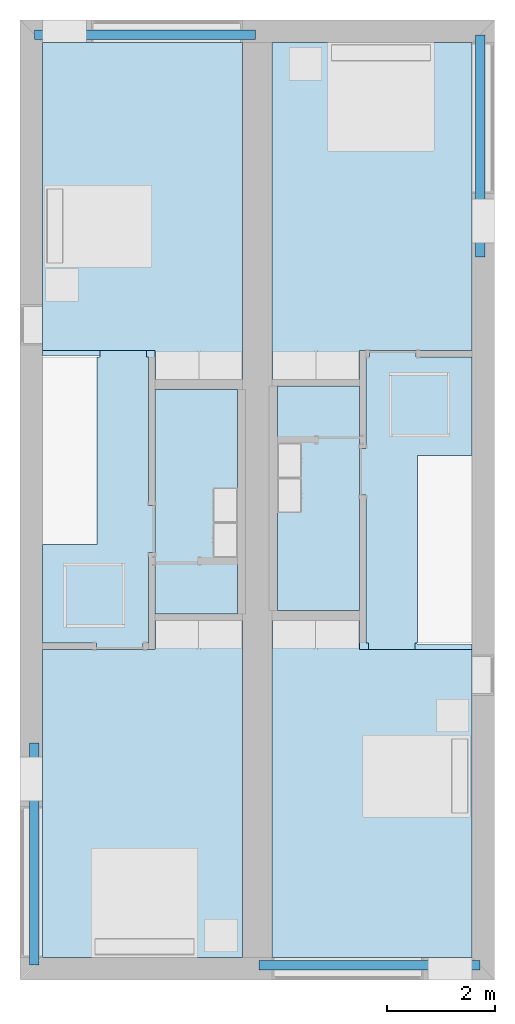
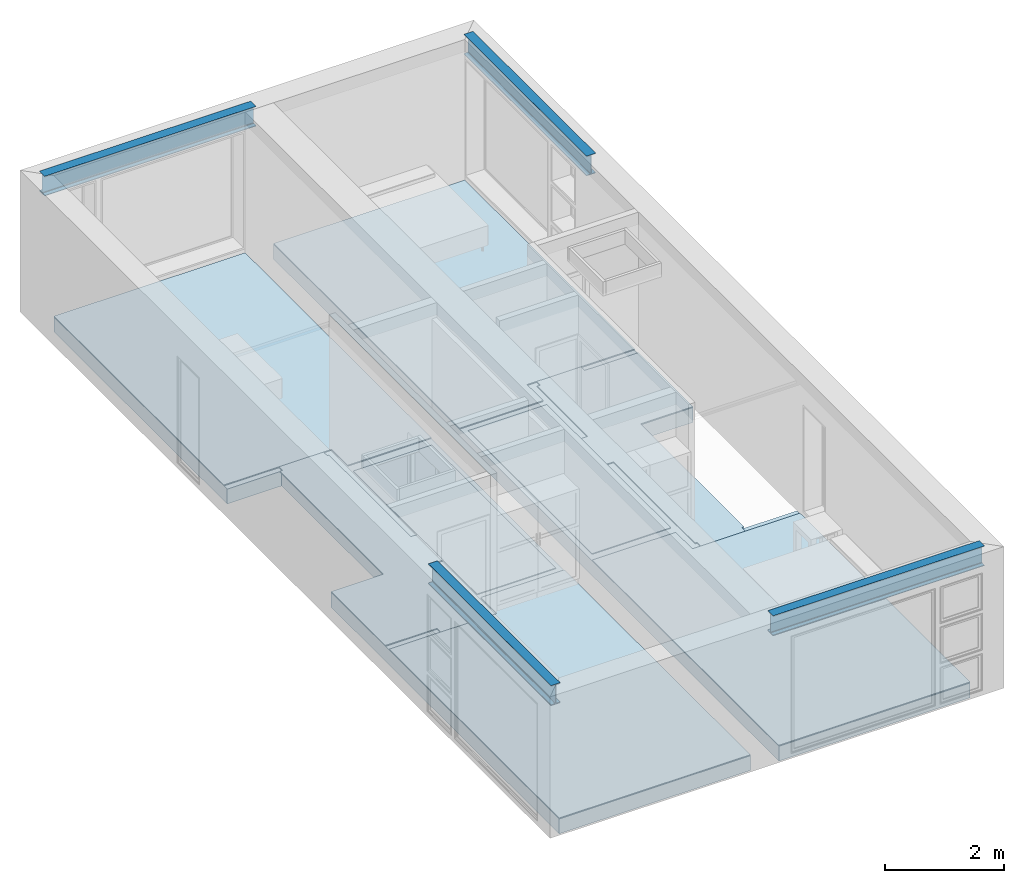
# One storey, part 1 of 16: 10 slabs, 4 beams.
"""IFC2X3 building model written with IfcOpenShell, lengths in metres."""

from ifc_helpers import new_model, entity, si_unit, converted_unit, frame, frame_2d, origin, place, context, project, spatial, polyline, circle_curve, parameter, trimmed, segment, composite_curve, rectangle, outline, extrude, material, layer, layer_set, layer_usage, element, save


model = new_model("IFC2X3")

# Units and contexts
model_context = context("Model", 3, precision=1e-09, world=origin())
plan_context = context("Plan", 3, precision=1e-09, world=origin())
ifc_project = project(units=[si_unit("LENGTHUNIT", "METRE"), si_unit("AREAUNIT", "SQUARE_METRE"), si_unit("VOLUMEUNIT", "CUBIC_METRE"), converted_unit("PLANEANGLEUNIT", "DEGREE", entity("IfcRatioMeasure", 0.01745329251994328), si_unit("PLANEANGLEUNIT", "RADIAN"), dimensions=[0, 0, 0, 0, 0, 0, 0]), si_unit("TIMEUNIT", "SECOND")], contexts=[model_context, plan_context])

# Site, building, storey
site_placement = place(None, origin())
site = spatial("IfcSite", under=ifc_project, at=site_placement, CompositionType="ELEMENT")
building_placement = place(site_placement, origin())
building = spatial("IfcBuilding", under=site, at=building_placement, CompositionType="ELEMENT")
storey_placement = place(building_placement, frame((0.0, 0.0, 3.100000000000378)))
storey = spatial("IfcBuildingStorey", under=building, at=storey_placement, Name="Level 2", CompositionType="ELEMENT", Elevation=3.100000000000378)

# Beams
ifc_material_1 = material(Name="Metal - Steel - 345 MPa")
beam_1_placement = place(storey_placement, frame((0.2666128795750488, -13.40172007136963, 2.89999999999983), z_axis=(0.0, 0.0, 1.0), x_axis=(-1.0, 0.0, 0.0)))
element("IfcBeam", 1, at=beam_1_placement, inside=storey, material=ifc_material_1, context=model_context, shape_type="SweptSolid", body=[
    extrude(outline(composite_curve([segment(polyline([(0.1906999999999978, -0.08900000000000018), (0.2034999999999992, -0.08900000000000018)]), True, "CONTINUOUS"), segment(polyline([(0.2034999999999992, -0.08900000000000018), (0.2034999999999992, 0.08900000000000004)]), True, "CONTINUOUS"), segment(polyline([(0.2034999999999992, 0.08900000000000004), (0.1906999999999978, 0.08900000000000004)]), True, "CONTINUOUS"), segment(polyline([(0.1906999999999978, 0.08900000000000004), (0.1906999999999978, 0.02104999999999999)]), True, "CONTINUOUS"), segment(trimmed(circle_curve(frame_2d((0.1734999999999985, 0.02104999999999992), x_axis=(1.0, 0.0)), 0.0172), [parameter(269.9999999999999)], [parameter(359.9999999999997)], True, "PARAMETER"), False, "CONTINUOUS"), segment(polyline([(0.1734999999999985, 0.003849999999999937), (-0.1735000000000017, 0.003849999999999937)]), True, "CONTINUOUS"), segment(trimmed(circle_curve(frame_2d((-0.1735000000000017, 0.02104999999999992), x_axis=(0.0, -1.0)), 0.0172), [parameter(269.9999999999999)], [parameter(359.9999999999999)], True, "PARAMETER"), False, "CONTINUOUS"), segment(polyline([(-0.1907000000000021, 0.02104999999999999), (-0.1907000000000021, 0.08900000000000004)]), True, "CONTINUOUS"), segment(polyline([(-0.1907000000000021, 0.08900000000000004), (-0.2035000000000014, 0.08900000000000004)]), True, "CONTINUOUS"), segment(polyline([(-0.2035000000000014, 0.08900000000000007), (-0.2035000000000014, -0.08899999999999963)]), True, "CONTINUOUS"), segment(polyline([(-0.2035000000000014, -0.08899999999999963), (-0.1907000000000021, -0.08899999999999963)]), True, "CONTINUOUS"), segment(polyline([(-0.1907000000000021, -0.08899999999999963), (-0.1907000000000021, -0.02105000000000012)]), True, "CONTINUOUS"), segment(trimmed(circle_curve(frame_2d((-0.1735000000000017, -0.02105000000000016), x_axis=(-1.0, 0.0)), 0.0172), [parameter(269.9999999999999)], [parameter(0.0)], True, "PARAMETER"), False, "CONTINUOUS"), segment(polyline([(-0.1735000000000017, -0.00385000000000014), (0.1734999999999985, -0.00385000000000014)]), True, "CONTINUOUS"), segment(trimmed(circle_curve(frame_2d((0.1734999999999985, -0.02105000000000016), x_axis=(0.0, 1.0)), 0.0172), [parameter(269.9999999999999)], [parameter(5.088887490341632e-14)], True, "PARAMETER"), False, "CONTINUOUS"), segment(polyline([(0.1906999999999978, -0.02105000000000012), (0.1906999999999978, -0.08900000000000018)]), True, "CONTINUOUS")], self_intersect=False)), frame((0.0, 4.121279928630347, -0.2035000000000068), z_axis=(0.0, -1.0, 0.0), x_axis=(0.0, 0.0, -1.0)), (0.0, 0.0, 1.0), 4.121279928630352),
])
beam_2_placement = place(storey_placement, frame((4.428954328744266, -17.52876686297367, 2.89999999999983), z_axis=(0.0, 0.0, 1.0), x_axis=(0.0, -1.0, 0.0)))
element("IfcBeam", 2, at=beam_2_placement, inside=storey, material=ifc_material_1, context=model_context, shape_type="SweptSolid", body=[
    extrude(outline(composite_curve([segment(polyline([(-0.08900000000000359, -0.1907), (-0.08900000000000359, -0.2035000000000014)]), True, "CONTINUOUS"), segment(polyline([(-0.08900000000000359, -0.2035000000000014), (0.0889999999999971, -0.2035000000000014)]), True, "CONTINUOUS"), segment(polyline([(0.0889999999999971, -0.2035000000000014), (0.0889999999999971, -0.1907)]), True, "CONTINUOUS"), segment(polyline([(0.0889999999999971, -0.1907), (0.02104999999999738, -0.1907)]), True, "CONTINUOUS"), segment(trimmed(circle_curve(frame_2d((0.02104999999999738, -0.1735000000000007), x_axis=(0.0, -1.0)), 0.0172), [parameter(269.9999999999999)], [parameter(359.9999999999997)], True, "PARAMETER"), False, "CONTINUOUS"), segment(polyline([(0.003849999999996959, -0.1735000000000007), (0.003849999999996959, 0.1734999999999995)]), True, "CONTINUOUS"), segment(trimmed(circle_curve(frame_2d((0.02104999999999738, 0.1734999999999995), x_axis=(-1.0, 0.0)), 0.0172), [parameter(269.9999999999999)], [parameter(359.9999999999999)], True, "PARAMETER"), False, "CONTINUOUS"), segment(polyline([(0.02104999999999522, 0.1907), (0.0889999999999971, 0.1907)]), True, "CONTINUOUS"), segment(polyline([(0.0889999999999971, 0.1907), (0.0889999999999971, 0.2034999999999992)]), True, "CONTINUOUS"), segment(polyline([(0.0889999999999971, 0.2034999999999992), (-0.08900000000000359, 0.2034999999999992)]), True, "CONTINUOUS"), segment(polyline([(-0.08900000000000359, 0.2034999999999992), (-0.08900000000000359, 0.1907)]), True, "CONTINUOUS"), segment(polyline([(-0.08900000000000359, 0.1907), (-0.02105000000000388, 0.1907)]), True, "CONTINUOUS"), segment(trimmed(circle_curve(frame_2d((-0.02105000000000388, 0.1734999999999995), x_axis=(0.0, 1.0)), 0.0172), [parameter(269.9999999999999)], [parameter(0.0)], True, "PARAMETER"), False, "CONTINUOUS"), segment(polyline([(-0.003850000000003457, 0.1734999999999995), (-0.003850000000003457, -0.1735000000000007)]), True, "CONTINUOUS"), segment(trimmed(circle_curve(frame_2d((-0.02105000000000388, -0.1735000000000007), x_axis=(1.0, 0.0)), 0.0172), [parameter(269.9999999999999)], [parameter(5.088887490341632e-14)], True, "PARAMETER"), False, "CONTINUOUS"), segment(polyline([(-0.02105000000000388, -0.1907), (-0.08900000000000359, -0.1907)]), True, "CONTINUOUS")], self_intersect=False)), frame((0.0, 0.0, -0.2035000000000046), z_axis=(0.0, -1.0, 0.0), x_axis=(1.0, 0.0, 0.0)), (0.0, 0.0, -1.0), 4.100000000000001),
])
beam_3_placement = place(storey_placement, frame((8.533387120424969, -4.398279928630386, 2.89999999999983)))
element("IfcBeam", 3, at=beam_3_placement, inside=storey, material=ifc_material_1, context=model_context, shape_type="SweptSolid", body=[
    extrude(outline(composite_curve([segment(polyline([(-0.08900000000000033, -0.1907), (-0.08900000000000033, -0.2035000000000014)]), True, "CONTINUOUS"), segment(polyline([(-0.08900000000000033, -0.2035000000000014), (0.08899999999999927, -0.2035000000000014)]), True, "CONTINUOUS"), segment(polyline([(0.08899999999999927, -0.2035000000000014), (0.08899999999999927, -0.1907)]), True, "CONTINUOUS"), segment(polyline([(0.08899999999999927, -0.1907), (0.02104999999999955, -0.1907)]), True, "CONTINUOUS"), segment(trimmed(circle_curve(frame_2d((0.02104999999999955, -0.1735000000000007), x_axis=(0.0, -1.0)), 0.0172), [parameter(269.9999999999999)], [parameter(359.9999999999997)], True, "PARAMETER"), False, "CONTINUOUS"), segment(polyline([(0.003849999999999125, -0.1735000000000007), (0.003849999999999125, 0.1734999999999995)]), True, "CONTINUOUS"), segment(trimmed(circle_curve(frame_2d((0.02104999999999955, 0.1734999999999995), x_axis=(-1.0, 0.0)), 0.0172), [parameter(269.9999999999999)], [parameter(359.9999999999999)], True, "PARAMETER"), False, "CONTINUOUS"), segment(polyline([(0.02104999999999955, 0.1907), (0.08899999999999927, 0.1907)]), True, "CONTINUOUS"), segment(polyline([(0.08899999999999927, 0.1907), (0.08899999999999927, 0.2034999999999992)]), True, "CONTINUOUS"), segment(polyline([(0.08899999999999927, 0.2034999999999992), (-0.08900000000000033, 0.2034999999999992)]), True, "CONTINUOUS"), segment(polyline([(-0.08900000000000033, 0.2034999999999992), (-0.08900000000000033, 0.1907)]), True, "CONTINUOUS"), segment(polyline([(-0.08900000000000033, 0.1907), (-0.02105000000000063, 0.1907)]), True, "CONTINUOUS"), segment(trimmed(circle_curve(frame_2d((-0.02105000000000063, 0.1734999999999995), x_axis=(0.0, 1.0)), 0.0172), [parameter(269.9999999999999)], [parameter(0.0)], True, "PARAMETER"), False, "CONTINUOUS"), segment(polyline([(-0.003850000000000208, 0.1734999999999995), (-0.003850000000000208, -0.1735000000000007)]), True, "CONTINUOUS"), segment(trimmed(circle_curve(frame_2d((-0.02105000000000063, -0.1735000000000007), x_axis=(1.0, 0.0)), 0.0172), [parameter(269.9999999999999)], [parameter(5.088887490341632e-14)], True, "PARAMETER"), False, "CONTINUOUS"), segment(polyline([(-0.02105000000000063, -0.1907), (-0.08900000000000033, -0.1907)]), True, "CONTINUOUS")], self_intersect=False)), frame((0.0, 0.0, -0.2035000000000046), z_axis=(0.0, -1.0, 0.0), x_axis=(1.0, 0.0, 0.0)), (0.0, 0.0, -1.0), 4.121279928630351),
])
beam_4_placement = place(storey_placement, frame((4.371045671255766, -0.2712331370263279, 2.89999999999983), z_axis=(0.0, 0.0, 1.0), x_axis=(0.0, 1.0, 0.0)))
element("IfcBeam", 4, at=beam_4_placement, inside=storey, material=ifc_material_1, context=model_context, shape_type="SweptSolid", body=[
    extrude(outline(composite_curve([segment(polyline([(0.1906999999999978, -0.08900000000000008), (0.2034999999999992, -0.08900000000000008)]), True, "CONTINUOUS"), segment(polyline([(0.2034999999999992, -0.08900000000000008), (0.2034999999999992, 0.08900000000000013)]), True, "CONTINUOUS"), segment(polyline([(0.2034999999999992, 0.08900000000000013), (0.1906999999999978, 0.08900000000000013)]), True, "CONTINUOUS"), segment(polyline([(0.1906999999999978, 0.08900000000000013), (0.1906999999999978, 0.02105000000000009)]), True, "CONTINUOUS"), segment(trimmed(circle_curve(frame_2d((0.1734999999999985, 0.02105000000000002), x_axis=(1.0, 0.0)), 0.0172), [parameter(269.9999999999999)], [parameter(359.9999999999997)], True, "PARAMETER"), False, "CONTINUOUS"), segment(polyline([(0.1734999999999985, 0.003850000000000039), (-0.1735000000000017, 0.003850000000000039)]), True, "CONTINUOUS"), segment(trimmed(circle_curve(frame_2d((-0.1735000000000017, 0.02105000000000002), x_axis=(0.0, -1.0)), 0.0172), [parameter(269.9999999999999)], [parameter(359.9999999999999)], True, "PARAMETER"), False, "CONTINUOUS"), segment(polyline([(-0.1907000000000021, 0.02105000000000009), (-0.1907000000000021, 0.08900000000000013)]), True, "CONTINUOUS"), segment(polyline([(-0.1907000000000021, 0.08900000000000013), (-0.2035000000000014, 0.08900000000000013)]), True, "CONTINUOUS"), segment(polyline([(-0.2035000000000014, 0.08900000000000016), (-0.2035000000000014, -0.08899999999999954)]), True, "CONTINUOUS"), segment(polyline([(-0.2035000000000014, -0.08899999999999954), (-0.1907000000000021, -0.08899999999999954)]), True, "CONTINUOUS"), segment(polyline([(-0.1907000000000021, -0.08899999999999954), (-0.1907000000000021, -0.02105000000000002)]), True, "CONTINUOUS"), segment(trimmed(circle_curve(frame_2d((-0.1735000000000017, -0.02105000000000006), x_axis=(-1.0, 0.0)), 0.0172), [parameter(269.9999999999999)], [parameter(0.0)], True, "PARAMETER"), False, "CONTINUOUS"), segment(polyline([(-0.1735000000000017, -0.003850000000000038), (0.1734999999999985, -0.003850000000000038)]), True, "CONTINUOUS"), segment(trimmed(circle_curve(frame_2d((0.1734999999999985, -0.02105000000000006), x_axis=(0.0, 1.0)), 0.0172), [parameter(269.9999999999999)], [parameter(5.088887490341632e-14)], True, "PARAMETER"), False, "CONTINUOUS"), segment(polyline([(0.1906999999999978, -0.02105000000000002), (0.1906999999999978, -0.08900000000000008)]), True, "CONTINUOUS")], self_intersect=False)), frame((0.0, 4.1, -0.2035000000000068), z_axis=(0.0, -1.0, 0.0), x_axis=(0.0, 0.0, -1.0)), (0.0, 0.0, 1.0), 4.100000000000001),
])

# Slabs
ifc_material_2 = material(Name="Wood - Sheathing - plywood")
ifc_layer_1 = layer(ifc_material_2, 0.019)
ifc_material_3 = material(Name="Wood - Dimensional Lumber")
ifc_layer_2 = layer(ifc_material_3, 0.286)
ifc_layer_set_1 = layer_set([ifc_layer_1, ifc_layer_2], Name="Floor:Residential - Wood Joist with")
ifc_layer_usage_1 = layer_usage(ifc_layer_set_1, "AXIS3", "POSITIVE", 0.0)
slab_1_placement = place(storey_placement, frame((0.4169999999999994, -17.38299999999999, -0.3050000000001818)))
element("IfcSlab", 5, at=slab_1_placement, inside=storey, material=ifc_layer_usage_1, Name="Floor:Residential - Wood Joist with", ObjectType="Floor:Residential - Wood Joist with", PredefinedType="FLOOR", context=model_context, shape_type="SweptSolid", body=[
    extrude(outline(polyline([(-1.854000000000013, 8.48299999999998), (-1.853999999999986, -8.482999999999993), (1.853999999999987, -8.482999999999981), (1.853999999999987, -0.8250000000000085), (0.799599999999962, -0.8250000000000117), (0.7995999999999563, 2.665999999999988), (1.853999999999987, 2.665999999999991), (1.853999999999986, 8.482999999999993), (-1.854000000000013, 8.48299999999998)])), frame((1.853999999999987, 8.482999999999993, 0.305), z_axis=(0.0, 0.0, -1.0), x_axis=(-1.0, 0.0, 0.0)), (0.0, 0.0, 1.0), 0.305),
])
ifc_layer_usage_2 = layer_usage(ifc_layer_set_1, "AXIS3", "POSITIVE", 0.0)
slab_2_placement = place(storey_placement, frame((4.674999999999998, -17.383, -0.3050000000001818)))
element("IfcSlab", 6, at=slab_2_placement, inside=storey, material=ifc_layer_usage_2, Name="Floor:Residential - Wood Joist with", ObjectType="Floor:Residential - Wood Joist with", PredefinedType="FLOOR", context=model_context, shape_type="SweptSolid", body=[
    extrude(outline(polyline([(-1.854000000000013, 8.48299999999998), (-1.854000000000001, 0.8250000000000031), (-0.829600000000002, 0.8250000000000063), (-0.8295999999999966, -2.665999999999991), (-1.853999999999995, -2.665999999999995), (-1.853999999999986, -8.482999999999992), (1.853999999999987, -8.482999999999981), (1.853999999999986, 8.482999999999992), (-1.854000000000013, 8.48299999999998)])), frame((1.853999999999987, 8.482999999999992, 0.305), z_axis=(0.0, 0.0, -1.0), x_axis=(-1.0, 0.0, 0.0)), (0.0, 0.0, 1.0), 0.305),
])
ifc_material_4 = material(Name="Wood - Flooring")
ifc_layer_3 = layer(ifc_material_4, 0.016)
ifc_material_5 = material(Name="Insulation / Thermal Barriers - Semi-rigid insulation")
ifc_layer_4 = layer(ifc_material_5, 0.003)
ifc_layer_set_2 = layer_set([ifc_layer_3, ifc_layer_4], Name="Floor:Finish Floor - Wood")
ifc_layer_usage_3 = layer_usage(ifc_layer_set_2, "AXIS3", "POSITIVE", 0.0)
slab_3_placement = place(storey_placement, frame((0.4169999999999989, -6.666000000000008, 0.0)))
element("IfcSlab", 7, at=slab_3_placement, inside=storey, material=ifc_layer_usage_3, Name="Floor:Finish Floor - Wood", ObjectType="Floor:Finish Floor - Wood", PredefinedType="FLOOR", context=model_context, shape_type="SweptSolid", body=[
    extrude(outline(polyline([(1.853999999999995, 3.124500000000004), (-1.854000000000005, 3.124499999999991), (-1.853999999999995, -3.124500000000002), (-0.235000000000004, -3.124499999999999), (-0.235000000000004, -2.584499999999999), (1.853999999999996, -2.584499999999999), (1.853999999999995, 3.124500000000004)])), frame((1.853999999999996, 3.124500000000002, 0.01900000000000001), z_axis=(0.0, 0.0, -1.0), x_axis=(-1.0, 0.0, 0.0)), (0.0, 0.0, 1.0), 0.01900000000000001),
])
ifc_layer_usage_4 = layer_usage(ifc_layer_set_2, "AXIS3", "POSITIVE", 0.0)
slab_4_placement = place(storey_placement, frame((4.675, -6.666000000000003, 0.0)))
element("IfcSlab", 8, at=slab_4_placement, inside=storey, material=ifc_layer_usage_4, Name="Floor:Finish Floor - Wood", ObjectType="Floor:Finish Floor - Wood", PredefinedType="FLOOR", context=model_context, shape_type="SweptSolid", body=[
    extrude(outline(polyline([(-1.854000000000005, 3.124499999999986), (-1.853999999999995, -2.584499999999996), (0.2349999999999791, -2.58449999999999), (0.2349999999999791, -3.124499999999991), (1.853999999999994, -3.124499999999991), (1.853999999999994, 3.124499999999997), (-1.854000000000005, 3.124499999999986)])), frame((1.853999999999994, 3.124499999999991, 0.01900000000000001), z_axis=(0.0, 0.0, -1.0), x_axis=(-1.0, 0.0, 0.0)), (0.0, 0.0, 1.0), 0.01900000000000001),
])
ifc_layer_usage_5 = layer_usage(ifc_layer_set_2, "AXIS3", "POSITIVE", 0.0)
slab_5_placement = place(storey_placement, frame((4.674999999999972, -17.383, 0.0)))
element("IfcSlab", 9, at=slab_5_placement, inside=storey, material=ifc_layer_usage_5, Name="Floor:Finish Floor - Wood", ObjectType="Floor:Finish Floor - Wood", PredefinedType="FLOOR", context=model_context, shape_type="SweptSolid", body=[
    extrude(outline(polyline([(-1.854000000000023, 2.576499999999997), (-1.853999999999994, -3.132499999999998), (1.854000000000005, -3.132499999999987), (1.853999999999995, 3.132499999999996), (0.2349999999999617, 3.132499999999996), (0.2349999999999617, 2.576499999999997), (-1.854000000000023, 2.576499999999997)])), frame((1.854000000000005, 3.132499999999998, 0.01900000000000001), z_axis=(0.0, 0.0, -1.0), x_axis=(-1.0, 0.0, 0.0)), (0.0, 0.0, 1.0), 0.01900000000000001),
])
ifc_layer_usage_6 = layer_usage(ifc_layer_set_2, "AXIS3", "POSITIVE", 0.0)
slab_6_placement = place(storey_placement, frame((0.4169999999999994, -17.38299999999999, 0.0)))
element("IfcSlab", 10, at=slab_6_placement, inside=storey, material=ifc_layer_usage_6, Name="Floor:Finish Floor - Wood", ObjectType="Floor:Finish Floor - Wood", PredefinedType="FLOOR", context=model_context, shape_type="SweptSolid", body=[
    extrude(outline(polyline([(-1.853999999999981, -3.124499999999998), (1.853999999999992, -3.124499999999987), (1.853999999999992, 2.584499999999991), (-0.2350000000000067, 2.584499999999984), (-0.2350000000000067, 3.124499999999985), (-1.854000000000009, 3.124499999999985), (-1.853999999999981, -3.124499999999998)])), frame((1.853999999999992, 3.124499999999998, 0.01900000000000001), z_axis=(0.0, 0.0, -1.0), x_axis=(-1.0, 0.0, 0.0)), (0.0, 0.0, 1.0), 0.01900000000000001),
])
ifc_layer_usage_7 = layer_usage(ifc_layer_set_2, "AXIS3", "POSITIVE", 0.0)
slab_7_placement = place(storey_placement, frame((0.4169999999999994, -11.674, 0.0)))
element("IfcSlab", 11, at=slab_7_placement, inside=storey, material=ifc_layer_usage_7, Name="Floor:Finish Floor - Wood", ObjectType="Floor:Finish Floor - Wood", PredefinedType="FLOOR", context=model_context, shape_type="SweptSolid", body=[
    extrude(outline(polyline([(-0.9205000000000011, -0.1060511785105842), (-1.0445, -0.1060511785105842), (-1.0445, -0.9700511785105828), (-0.9205000000000011, -0.9700511785105828), (-0.9205000000000011, -2.649999999999998), (-0.8204999999999938, -2.649999999999998), (-0.8204999999999935, -2.774), (0.04350000000000635, -2.773999999999995), (0.04350000000000608, -2.649999999999998), (1.0445, -2.649999999999993), (1.0445, -0.8249999999999998), (0.03009999999999938, -0.825000000000002), (0.03009999999999126, 2.649999999999999), (-0.02179999999999559, 2.649999999999999), (-0.02179999999999613, 2.773999999999999), (-0.8857999999999965, 2.773999999999997), (-0.885799999999996, 2.650000000000002), (-0.9205000000000011, 2.650000000000002), (-0.9205000000000011, -0.1060511785105842)])), frame((1.0445, 2.774, 0.01900000000000001), z_axis=(0.0, 0.0, -1.0), x_axis=(-1.0, 0.0, 0.0)), (0.0, 0.0, 1.0), 0.01900000000000001),
])
ifc_layer_usage_8 = layer_usage(ifc_layer_set_2, "AXIS3", "POSITIVE", 0.0)
slab_8_placement = place(storey_placement, frame((6.294000000000013, -11.67400000000001, 0.0)))
element("IfcSlab", 12, at=slab_8_placement, inside=storey, material=ifc_layer_usage_8, Name="Floor:Finish Floor - Wood", ObjectType="Floor:Finish Floor - Wood", PredefinedType="FLOOR", context=model_context, shape_type="SweptSolid", body=[
    extrude(outline(polyline([(0.9205000000000149, 0.09061576492848053), (1.044499999999974, 0.09061576492848161), (1.044499999999972, 0.9546157649284801), (0.9204999999999943, 0.9546157649284801), (0.9204999999999889, 2.650000000000002), (0.8604999999999787, 2.650000000000002), (0.8604999999999787, 2.774000000000003), (-0.003500000000020862, 2.773999999999997), (-0.003500000000020862, 2.649999999999998), (-1.044499999999993, 2.649999999999991), (-1.044499999999988, 0.8249999999999976), (-0.03010000000000182, 0.8250000000000031), (-0.03009999999998233, -2.649999999999998), (0.01720000000000151, -2.649999999999998), (0.01720000000000259, -2.773999999999997), (0.8812000000000033, -2.773999999999991), (0.8812000000000022, -2.649999999999989), (0.9205000000000235, -2.649999999999989), (0.9205000000000149, 0.09061576492848053)])), frame((1.044499999999974, 2.773999999999997, 0.01900000000000001), z_axis=(0.0, 0.0, -1.0), x_axis=(-1.0, 0.0, 0.0)), (0.0, 0.0, 1.0), 0.01900000000000001),
])
ifc_material_6 = material(Name="Ceramic Tile")
ifc_layer_5 = layer(ifc_material_6, 0.01)
ifc_material_7 = material(Name="Masonry - Grout")
ifc_layer_6 = layer(ifc_material_7, 0.003)
ifc_layer_set_3 = layer_set([ifc_layer_5, ifc_layer_6], Name="Floor:Finish Floor - Ceramic Tile")
ifc_layer_usage_9 = layer_usage(ifc_layer_set_3, "AXIS3", "POSITIVE", 0.0)
slab_9_placement = place(storey_placement, frame((2.505999999999992, -11.01, 0.0)))
element("IfcSlab", 13, at=slab_9_placement, inside=storey, material=ifc_layer_usage_9, Name="Floor:Finish Floor - Ceramic Tile", ObjectType="Floor:Finish Floor - Ceramic Tile", PredefinedType="FLOOR", context=model_context, shape_type="SweptSolid", body=[
    extrude(rectangle(XDim=4.16, YDim=1.523999999999994, at=frame_2d((0.0, 0.0), x_axis=(0.0, -1.0))), frame((0.7619999999999968, 2.080000000000001, 0.01299999999999975), z_axis=(0.0, 0.0, -1.0), x_axis=(-1.0, 0.0, 0.0)), (0.0, 0.0, 1.0), 0.01299999999999975),
])
ifc_layer_usage_10 = layer_usage(ifc_layer_set_3, "AXIS3", "POSITIVE", 0.0)
slab_10_placement = place(storey_placement, frame((4.769999999999986, -10.95000000000001, 0.0)))
element("IfcSlab", 14, at=slab_10_placement, inside=storey, material=ifc_layer_usage_10, Name="Floor:Finish Floor - Ceramic Tile", ObjectType="Floor:Finish Floor - Ceramic Tile", PredefinedType="FLOOR", context=model_context, shape_type="SweptSolid", body=[
    extrude(rectangle(XDim=4.160000000000009, YDim=1.524000000000014, at=frame_2d((0.0, 0.0), x_axis=(0.0, -1.0))), frame((0.7620000000000071, 2.080000000000005, 0.01299999999999975), z_axis=(0.0, 0.0, -1.0), x_axis=(-1.0, 0.0, 0.0)), (0.0, 0.0, 1.0), 0.01299999999999975),
])

save(model, "model.ifc")
